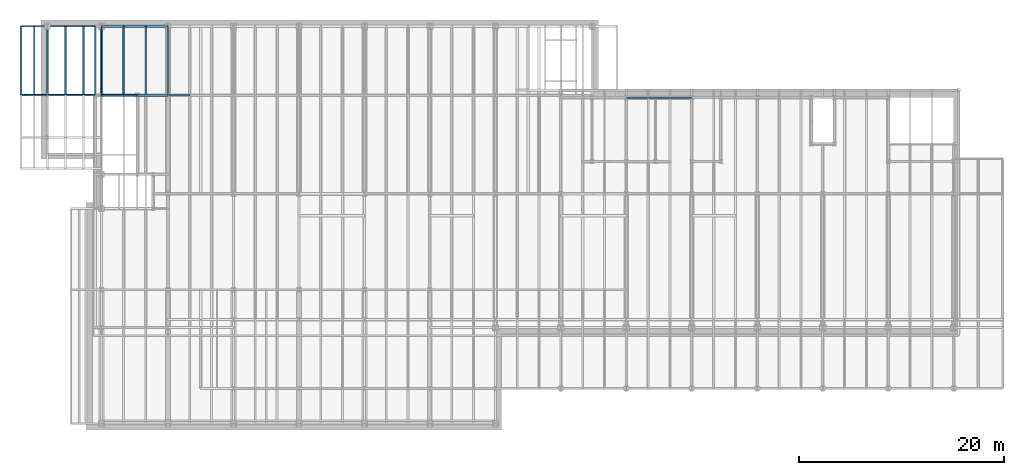
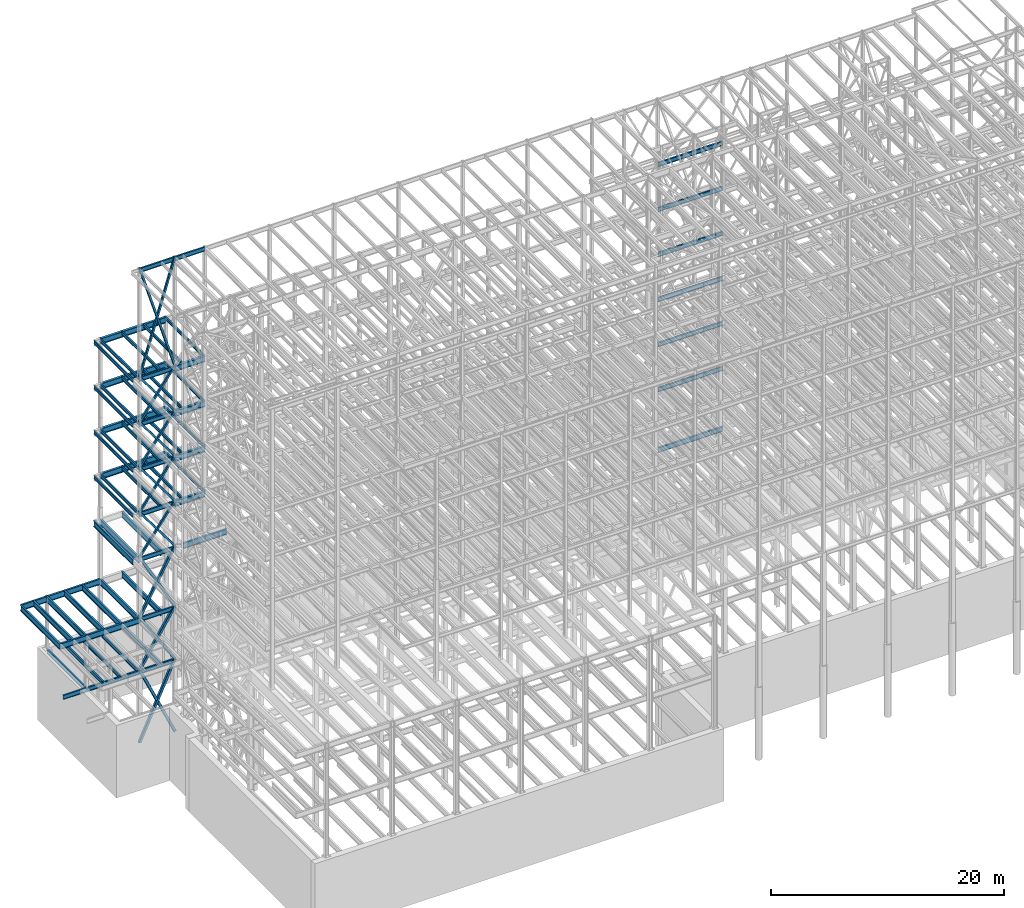
# One storey, part 136 of 150: 81 beams.
"""IFC2X3 building model written with IfcOpenShell, lengths in millimetres."""

import ifcopenshell
import ifcopenshell.guid

model = None  # the IFC model being written
_history = None  # IfcOwnerHistory: only IFC2X3 demands one
_inside = {}  # id of a spatial element -> (the spatial element, [elements in it])
_under = {}  # id of a project, library or spatial element -> (it, [spatial elements below it])
_declared = {}  # id of a project -> (the project, [libraries it declares])
_typed = {}  # id of a type object -> (the type object, [elements of that type])
_made_of = {}  # id of a material, layer set ... -> (it, [elements and type objects made of it])


def new_model(schema):
    """Start an empty IFC model of exactly this schema.

    Asked for "IFC4X3", IfcOpenShell would pick the latest addendum, in which some entities
    have other attributes; the version numbers below select the first issue.
    IFC2X3 requires an IfcOwnerHistory on every rooted entity: one is made here for all.
    """
    global model, _history
    if schema == "IFC4X3":
        model = ifcopenshell.file(schema_version=(4, 3, 0, 0))
    else:
        model = ifcopenshell.file(schema=schema)
    _inside.clear()
    _under.clear()
    _declared.clear()
    _typed.clear()
    _made_of.clear()
    _history = None
    if model.schema == "IFC2X3":
        org = make("IfcOrganization", Name="unknown")
        user = make(
            "IfcPersonAndOrganization",
            ThePerson=make("IfcPerson", FamilyName="unknown"),
            TheOrganization=org,
        )
        app = make(
            "IfcApplication",
            ApplicationDeveloper=org,
            Version="unknown",
            ApplicationFullName="unknown",
            ApplicationIdentifier="unknown",
        )
        _history = make(
            "IfcOwnerHistory",
            OwningUser=user,
            OwningApplication=app,
            ChangeAction="ADDED",
            CreationDate=0,
        )
    return model


def make(cls, **values):
    """One entity of the class cls with the attributes given. An attribute that is None is left unset."""
    return model.create_entity(
        cls, **{name: value for name, value in values.items() if value is not None}
    )


def rooted(cls, **values):
    """An entity with a GlobalId (a new one), such as an element, a storey or a relation."""
    return make(cls, GlobalId=ifcopenshell.guid.new(), OwnerHistory=_history, **values)


def si_unit(unit_type, name, prefix=None):
    """IfcSIUnit, for example si_unit("LENGTHUNIT", "METRE", prefix="MILLI")."""
    return make("IfcSIUnit", UnitType=unit_type, Prefix=prefix, Name=name)


def assignment(units):
    """IfcUnitAssignment: the units of a project."""
    return None if units is None else make("IfcUnitAssignment", Units=units)


def point(xyz):
    """IfcCartesianPoint."""
    return None if xyz is None else make("IfcCartesianPoint", Coordinates=xyz)


def direction(xyz):
    """IfcDirection."""
    return None if xyz is None else make("IfcDirection", DirectionRatios=xyz)


def frame(location, z_axis=None, x_axis=None):
    """IfcAxis2Placement3D, a coordinate frame: its origin and axes. An axis left out is left unset."""
    return make(
        "IfcAxis2Placement3D",
        Location=point(location),
        Axis=direction(z_axis),
        RefDirection=direction(x_axis),
    )


def frame_2d(location, x_axis=None):
    """IfcAxis2Placement2D, a coordinate frame in the plane: its origin and x axis."""
    return make(
        "IfcAxis2Placement2D", Location=point(location), RefDirection=direction(x_axis)
    )


def origin_with_axes():
    """The frame at (0, 0, 0) with the z axis (0, 0, 1) and the x axis (1, 0, 0) written out."""
    return frame((0.0, 0.0, 0.0), z_axis=(0.0, 0.0, 1.0), x_axis=(1.0, 0.0, 0.0))


def origin_2d_with_axis():
    """The frame at (0, 0) in the plane with the x axis (1, 0) written out."""
    return frame_2d((0.0, 0.0), x_axis=(1.0, 0.0))


def place(relative_to, where):
    """IfcLocalPlacement: puts the frame where relative to a parent placement (None: the world)."""
    return make(
        "IfcLocalPlacement", PlacementRelTo=relative_to, RelativePlacement=where
    )


def context(
    kind, dimensions, precision=None, world=None, true_north=None, identifier=None
):
    """IfcGeometricRepresentationContext, for example the 3D "Model" context."""
    return make(
        "IfcGeometricRepresentationContext",
        ContextIdentifier=identifier,
        ContextType=kind,
        CoordinateSpaceDimension=dimensions,
        Precision=precision,
        WorldCoordinateSystem=world,
        TrueNorth=true_north,
    )


def subcontext(parent, identifier, kind, view, scale=None):
    """IfcGeometricRepresentationSubContext, for example "Body" below "Model"."""
    return make(
        "IfcGeometricRepresentationSubContext",
        ContextIdentifier=identifier,
        ContextType=kind,
        ParentContext=parent,
        TargetScale=scale,
        TargetView=view,
    )


def project(units=None, contexts=None):
    """IfcProject with its units and contexts."""
    return rooted(
        "IfcProject",
        Name="project",
        RepresentationContexts=contexts,
        UnitsInContext=assignment(units),
    )


def spatial(cls, under=None, at=None, **own):
    """A site, building, storey or space (cls), placed at a placement, below another one or the project."""
    s = rooted(cls, ObjectPlacement=at, **own)
    if under is not None:
        _under.setdefault(under.id(), (under, []))[1].append(s)
    return s


def profile(cls, at=None, kind="AREA", **sizes):
    """A parametric profile (cls). Its sizes go by their IFC names, for example OverallWidth=200.0."""
    return make(cls, ProfileType=kind, Position=at, **sizes)


def hollow_rectangle(**sizes):
    """IfcRectangleHollowProfileDef."""
    return profile("IfcRectangleHollowProfileDef", **sizes)


def i_section(**sizes):
    """IfcIShapeProfileDef."""
    return profile("IfcIShapeProfileDef", **sizes)


def extrude(swept, where, along, depth):
    """IfcExtrudedAreaSolid: the profile swept, set in the frame where, extruded along a direction by depth."""
    return make(
        "IfcExtrudedAreaSolid",
        SweptArea=swept,
        Position=where,
        ExtrudedDirection=direction(along),
        Depth=depth,
    )


def shape(context_of_items, identifier, shape_type, items):
    """IfcShapeRepresentation: the items that make up one representation, for example the "Body"."""
    return make(
        "IfcShapeRepresentation",
        ContextOfItems=context_of_items,
        RepresentationIdentifier=identifier,
        RepresentationType=shape_type,
        Items=items,
    )


def material(Name=None, Category=None):
    """IfcMaterial."""
    return make("IfcMaterial", Name=Name, Category=Category)


def made_of(thing, what):
    """Note that an element or type object is made of a material, layer set ...; save() writes the relation."""
    if what is not None:
        _made_of.setdefault(what.id(), (what, []))[1].append(thing)
    return thing


def type_object(cls, material=None, **own):
    """A type object (cls), such as IfcWallType, which elements share."""
    return made_of(rooted(cls, **own), material)


def element(
    cls,
    number,
    at=None,
    inside=None,
    cuts=None,
    type_object=None,
    material=None,
    context=None,
    identifier="Body",
    shape_type=None,
    held_by="IfcProductDefinitionShape",
    body=None,
    shapes=None,
    **own,
):
    """One element of the class cls, such as IfcWall. Its Tag is "e" and its number.

    at: its placement. inside: the storey or other place that contains it. cuts: it is an
    opening in that element (IfcRelVoidsElement). A single representation is given by context,
    identifier, shape_type and body (its items); several are given by shapes. held_by: the class
    of the entity that holds the representations. save() writes the other relations.
    """
    e = rooted(cls, Tag="e%d" % number, ObjectPlacement=at, **own)
    if body is not None:
        shapes = [shape(context, identifier, shape_type, body)]
    if shapes is not None:
        e.Representation = make(held_by, Representations=shapes)
    if inside is not None:
        _inside.setdefault(inside.id(), (inside, []))[1].append(e)
    if cuts is not None:
        rooted(
            "IfcRelVoidsElement", RelatingBuildingElement=cuts, RelatedOpeningElement=e
        )
    if type_object is not None:
        _typed.setdefault(type_object.id(), (type_object, []))[1].append(e)
    return made_of(e, material)


def aggregate(whole, parts):
    """IfcRelAggregates: a whole, such as a stair, and the parts it consists of."""
    return rooted("IfcRelAggregates", RelatingObject=whole, RelatedObjects=parts)


def save(model, path):
    """Write the relations noted so far, then the file.

    IfcRelAggregates (storeys below a building ...), IfcRelContainedInSpatialStructure (elements
    in a storey), IfcRelDefinesByType, IfcRelAssociatesMaterial and IfcRelDeclares: one each for
    every whole, place, type object, material and project.
    """
    for whole, parts in _under.values():
        aggregate(whole, parts)
    for where, things in _inside.values():
        rooted(
            "IfcRelContainedInSpatialStructure",
            RelatedElements=things,
            RelatingStructure=where,
        )
    for kind, things in _typed.values():
        rooted("IfcRelDefinesByType", RelatedObjects=things, RelatingType=kind)
    for what, things in _made_of.values():
        rooted("IfcRelAssociatesMaterial", RelatedObjects=things, RelatingMaterial=what)
    for by, libraries in _declared.values():
        rooted("IfcRelDeclares", RelatingContext=by, RelatedDefinitions=libraries)
    model.write(path)


model = new_model("IFC2X3")

# Units and contexts
model_context = context("Model", 3, precision=1e-05, world=origin_with_axes())
body_context = subcontext(model_context, "Body", "Model", "MODEL_VIEW")
ifc_project = project(units=[si_unit("LENGTHUNIT", "METRE", prefix="MILLI"), si_unit("AREAUNIT", "SQUARE_METRE"), si_unit("VOLUMEUNIT", "CUBIC_METRE"), si_unit("MASSUNIT", "GRAM", prefix="KILO"), si_unit("TIMEUNIT", "SECOND"), si_unit("PLANEANGLEUNIT", "RADIAN"), si_unit("SOLIDANGLEUNIT", "STERADIAN"), si_unit("THERMODYNAMICTEMPERATUREUNIT", "DEGREE_CELSIUS"), si_unit("LUMINOUSINTENSITYUNIT", "LUMEN")], contexts=[model_context])

# Site, building, storey
site_placement = place(None, origin_with_axes())
site = spatial("IfcSite", under=ifc_project, at=site_placement, CompositionType="ELEMENT")
building_placement = place(site_placement, origin_with_axes())
building = spatial("IfcBuilding", under=site, at=building_placement, Name="Undefined", CompositionType="ELEMENT")
storey_placement = place(building_placement, origin_with_axes())
storey = spatial("IfcBuildingStorey", under=building, at=storey_placement, Name="Undefined", CompositionType="ELEMENT", Elevation=0.0)

# Beams
ifc_material_1 = material()
beam_type_1 = type_object("IfcBeamType", Name="HSS8X8X3/8", PredefinedType="NOTDEFINED")
beam_1_placement = place(storey_placement, frame((8788.39896651539, 32131.0, 54482.99942554), z_axis=(0.956054251549644, 0.0, 0.293189815808549), x_axis=(-0.293189815808549, 0.0, 0.956054251549644)))
element("IfcBeam", 1, at=beam_1_placement, inside=storey, type_object=beam_type_1, material=ifc_material_1, Name="BEAM", ObjectType="HSS8X8X3/8", context=body_context, shape_type="SweptSolid", body=[
    extrude(hollow_rectangle(XDim=203.2, YDim=203.2, WallThickness=9.525, InnerFilletRadius=9.5249, OuterFilletRadius=19.0499, at=origin_2d_with_axis()), frame((11955.3892837769, -7.27595761418343e-12, -3.63797880709171e-12), z_axis=(-1.0, 0.0, 0.0), x_axis=(0.0, -1.0, 0.0)), (0.0, 0.0, 1.0), 11955.3892837769),
])
beam_2_placement = place(storey_placement, frame((5283.2, 32131.0, 54483.0), z_axis=(-0.956054251549644, 0.0, 0.293189815808549), x_axis=(0.293189815808549, 0.0, 0.956054251549644)))
element("IfcBeam", 2, at=beam_2_placement, inside=storey, type_object=beam_type_1, material=ifc_material_1, Name="BEAM", ObjectType="HSS8X8X3/8", context=body_context, shape_type="SweptSolid", body=[
    extrude(hollow_rectangle(XDim=203.2, YDim=203.2, WallThickness=9.525, InnerFilletRadius=9.5249, OuterFilletRadius=19.0499, at=origin_2d_with_axis()), frame((11955.3887873842, 0.0, 0.0), z_axis=(-1.0, 0.0, 0.0), x_axis=(0.0, -1.0, 0.0)), (0.0, 0.0, 1.0), 11955.3887873842),
])
beam_3_placement = place(storey_placement, frame((8788.39896651539, 32131.0, 40309.79942554), z_axis=(0.803098244341145, 0.0, 0.595846632898241), x_axis=(-0.595846632898242, 0.0, 0.803098244341144)))
element("IfcBeam", 3, at=beam_3_placement, inside=storey, type_object=beam_type_1, material=ifc_material_1, Name="BEAM", ObjectType="HSS8X8X3/8", context=body_context, shape_type="SweptSolid", body=[
    extrude(hollow_rectangle(XDim=203.2, YDim=203.2, WallThickness=9.525, InnerFilletRadius=9.5249, OuterFilletRadius=19.0499, at=origin_2d_with_axis()), frame((5882.7188087498, 0.0, 6.94940112073995e-12), z_axis=(-1.0, 0.0, 0.0), x_axis=(0.0, -1.0, 0.0)), (0.0, 0.0, 1.0), 5882.71880874979),
])
beam_4_placement = place(storey_placement, frame((5283.2, 32131.0, 40309.8), z_axis=(-0.803098029777427, 0.0, 0.595846922092927), x_axis=(0.595846922092929, 0.0, 0.803098029777426)))
element("IfcBeam", 4, at=beam_4_placement, inside=storey, type_object=beam_type_1, material=ifc_material_1, Name="BEAM", ObjectType="HSS8X8X3/8", context=body_context, shape_type="SweptSolid", body=[
    extrude(hollow_rectangle(XDim=203.2, YDim=203.2, WallThickness=9.525, InnerFilletRadius=9.5249, OuterFilletRadius=19.0499, at=origin_2d_with_axis()), frame((5882.71896592564, 0.0, 0.0), z_axis=(-1.0, 0.0, 0.0), x_axis=(0.0, -1.0, 0.0)), (0.0, 0.0, 1.0), 5882.71896592564),
])
beam_5_placement = place(storey_placement, frame((8788.39786397127, 32131.0, 35585.3995776807), z_axis=(0.803098244341145, 0.0, 0.595846632898241), x_axis=(-0.595846632898242, 0.0, 0.803098244341144)))
element("IfcBeam", 5, at=beam_5_placement, inside=storey, type_object=beam_type_1, material=ifc_material_1, Name="BEAM", ObjectType="HSS8X8X3/8", context=body_context, shape_type="SweptSolid", body=[
    extrude(hollow_rectangle(XDim=203.2, YDim=203.2, WallThickness=9.525, InnerFilletRadius=9.5249, OuterFilletRadius=19.0499, at=origin_2d_with_axis()), frame((5882.71803696899, 0.0, 0.0), z_axis=(-1.0, 0.0, 0.0), x_axis=(0.0, -1.0, 0.0)), (0.0, 0.0, 1.0), 5882.71802961862),
])
beam_6_placement = place(storey_placement, frame((5283.2, 32131.0, 35585.4), z_axis=(-0.803098029777427, 0.0, 0.595846922092927), x_axis=(0.595846922092929, 0.0, 0.803098029777426)))
element("IfcBeam", 6, at=beam_6_placement, inside=storey, type_object=beam_type_1, material=ifc_material_1, Name="BEAM", ObjectType="HSS8X8X3/8", context=body_context, shape_type="SweptSolid", body=[
    extrude(hollow_rectangle(XDim=203.2, YDim=203.2, WallThickness=9.525, InnerFilletRadius=9.5249, OuterFilletRadius=19.0499, at=origin_2d_with_axis()), frame((5882.71845468122, 3.63797880709171e-12, -3.63797880709171e-12), z_axis=(-1.0, 0.0, 0.0), x_axis=(0.0, -1.0, 0.0)), (0.0, 0.0, 1.0), 5882.71845468121),
])
ifc_material_2 = material(Name="STEEL/A992")
beam_type_2 = type_object("IfcBeamType", Name="W18X35", PredefinedType="NOTDEFINED")
beam_7_placement = place(storey_placement, frame((8788.39949708, 32130.9985242539, 65687.575), z_axis=(0.0, 0.0, 1.0), x_axis=(1.0, 0.0, 0.0)))
element("IfcBeam", 7, at=beam_7_placement, inside=storey, type_object=beam_type_2, material=ifc_material_2, Name="BEAM", ObjectType="W18X35", context=body_context, shape_type="SweptSolid", body=[
    extrude(i_section(OverallWidth=152.4, OverallDepth=450.85, WebThickness=7.9375, FlangeThickness=10.795, FilletRadius=17.78, at=origin_2d_with_axis()), frame((2997.20050292036, 0.0, 1.45519152283669e-11), z_axis=(-1.0, 0.0, 0.0), x_axis=(0.0, -1.0, 0.0)), (0.0, 0.0, 1.0), 2997.20050292036),
])
beam_8_placement = place(storey_placement, frame((5283.2, 32131.0, 65687.575), z_axis=(0.0, 0.0, 1.0), x_axis=(1.0, 0.0, 0.0)))
element("IfcBeam", 8, at=beam_8_placement, inside=storey, type_object=beam_type_2, material=ifc_material_2, Name="BEAM", ObjectType="W18X35", context=body_context, shape_type="SweptSolid", body=[
    extrude(i_section(OverallWidth=152.4, OverallDepth=450.85, WebThickness=7.9375, FlangeThickness=10.795, FilletRadius=17.78, at=origin_2d_with_axis()), frame((3505.19914656064, 0.0, 1.45519152283669e-11), z_axis=(-1.0, 0.0, 0.0), x_axis=(0.0, -1.0, 0.0)), (0.0, 0.0, 1.0), 3505.19914656064),
])
beam_9_placement = place(storey_placement, frame((56591.2, 31877.0, 58981.975), z_axis=(0.0, 0.0, 1.0), x_axis=(1.0, 0.0, 0.0)))
element("IfcBeam", 9, at=beam_9_placement, inside=storey, type_object=beam_type_2, material=ifc_material_2, Name="BEAM", ObjectType="W18X35", context=body_context, shape_type="SweptSolid", body=[
    extrude(i_section(OverallWidth=152.4, OverallDepth=450.85, WebThickness=7.9375, FlangeThickness=10.795, FilletRadius=17.78, at=origin_2d_with_axis()), frame((6400.80000000001, 0.0, 0.0), z_axis=(-1.0, 0.0, 0.0), x_axis=(0.0, -1.0, 0.0)), (0.0, 0.0, 1.0), 6400.80000000001),
])
beam_10_placement = place(storey_placement, frame((5283.2, 32131.0, 54257.575), z_axis=(0.0, 0.0, 1.0), x_axis=(1.0, 0.0, 0.0)))
element("IfcBeam", 10, at=beam_10_placement, inside=storey, type_object=beam_type_2, material=ifc_material_2, Name="BEAM", ObjectType="W18X35", context=body_context, shape_type="SweptSolid", body=[
    extrude(i_section(OverallWidth=152.4, OverallDepth=450.85, WebThickness=7.9375, FlangeThickness=10.795, FilletRadius=17.78, at=origin_2d_with_axis()), frame((3505.19844552055, 0.0, 0.0), z_axis=(-1.0, 0.0, 0.0), x_axis=(0.0, -1.0, 0.0)), (0.0, 0.0, 1.0), 3505.19844552055),
])
beam_11_placement = place(storey_placement, frame((56591.2, 31877.0, 54257.575), z_axis=(0.0, 0.0, 1.0), x_axis=(1.0, 0.0, 0.0)))
element("IfcBeam", 11, at=beam_11_placement, inside=storey, type_object=beam_type_2, material=ifc_material_2, Name="BEAM", ObjectType="W18X35", context=body_context, shape_type="SweptSolid", body=[
    extrude(i_section(OverallWidth=152.4, OverallDepth=450.85, WebThickness=7.9375, FlangeThickness=10.795, FilletRadius=17.78, at=origin_2d_with_axis()), frame((6400.80000000001, 0.0, 0.0), z_axis=(-1.0, 0.0, 0.0), x_axis=(0.0, -1.0, 0.0)), (0.0, 0.0, 1.0), 6400.8),
])
beam_12_placement = place(storey_placement, frame((5283.2, 32131.0, 49533.175), z_axis=(0.0, 0.0, 1.0), x_axis=(1.0, 0.0, 0.0)))
element("IfcBeam", 12, at=beam_12_placement, inside=storey, type_object=beam_type_2, material=ifc_material_2, Name="BEAM", ObjectType="W18X35", context=body_context, shape_type="SweptSolid", body=[
    extrude(i_section(OverallWidth=152.4, OverallDepth=450.85, WebThickness=7.9375, FlangeThickness=10.795, FilletRadius=17.78, at=origin_2d_with_axis()), frame((3505.19879604036, 0.0, 0.0), z_axis=(-1.0, 0.0, 0.0), x_axis=(0.0, -1.0, 0.0)), (0.0, 0.0, 1.0), 3505.19879604036),
])
beam_13_placement = place(storey_placement, frame((56591.2, 31877.0, 49533.175), z_axis=(0.0, 0.0, 1.0), x_axis=(1.0, 0.0, 0.0)))
element("IfcBeam", 13, at=beam_13_placement, inside=storey, type_object=beam_type_2, material=ifc_material_2, Name="BEAM", ObjectType="W18X35", context=body_context, shape_type="SweptSolid", body=[
    extrude(i_section(OverallWidth=152.4, OverallDepth=450.85, WebThickness=7.9375, FlangeThickness=10.795, FilletRadius=17.78, at=origin_2d_with_axis()), frame((6400.80000000001, 0.0, 0.0), z_axis=(-1.0, 0.0, 0.0), x_axis=(0.0, -1.0, 0.0)), (0.0, 0.0, 1.0), 6400.8),
])
beam_14_placement = place(storey_placement, frame((5283.2, 32131.0, 44808.775), z_axis=(0.0, 0.0, 1.0), x_axis=(1.0, 0.0, 0.0)))
element("IfcBeam", 14, at=beam_14_placement, inside=storey, type_object=beam_type_2, material=ifc_material_2, Name="BEAM", ObjectType="W18X35", context=body_context, shape_type="SweptSolid", body=[
    extrude(i_section(OverallWidth=152.4, OverallDepth=450.85, WebThickness=7.9375, FlangeThickness=10.795, FilletRadius=17.78, at=origin_2d_with_axis()), frame((3505.19914656064, 0.0, 1.45519152283669e-11), z_axis=(-1.0, 0.0, 0.0), x_axis=(0.0, -1.0, 0.0)), (0.0, 0.0, 1.0), 3505.1991465602),
])
beam_15_placement = place(storey_placement, frame((56591.2, 31877.0, 44808.775), z_axis=(0.0, 0.0, 1.0), x_axis=(1.0, 0.0, 0.0)))
element("IfcBeam", 15, at=beam_15_placement, inside=storey, type_object=beam_type_2, material=ifc_material_2, Name="BEAM", ObjectType="W18X35", context=body_context, shape_type="SweptSolid", body=[
    extrude(i_section(OverallWidth=152.4, OverallDepth=450.85, WebThickness=7.9375, FlangeThickness=10.795, FilletRadius=17.78, at=origin_2d_with_axis()), frame((6400.80000000001, 0.0, 0.0), z_axis=(-1.0, 0.0, 0.0), x_axis=(0.0, -1.0, 0.0)), (0.0, 0.0, 1.0), 6400.8),
])
beam_16_placement = place(storey_placement, frame((5283.2, 32131.0, 40084.375), z_axis=(0.0, 0.0, 1.0), x_axis=(1.0, 0.0, 0.0)))
element("IfcBeam", 16, at=beam_16_placement, inside=storey, type_object=beam_type_2, material=ifc_material_2, Name="BEAM", ObjectType="W18X35", context=body_context, shape_type="SweptSolid", body=[
    extrude(i_section(OverallWidth=152.4, OverallDepth=450.85, WebThickness=7.9375, FlangeThickness=10.795, FilletRadius=17.78, at=origin_2d_with_axis()), frame((3505.19949708, 0.0, 0.0), z_axis=(-1.0, 0.0, 0.0), x_axis=(0.0, -1.0, 0.0)), (0.0, 0.0, 1.0), 3505.19949708008),
])
beam_17_placement = place(storey_placement, frame((56591.2, 31877.0, 40084.375), z_axis=(0.0, 0.0, 1.0), x_axis=(1.0, 0.0, 0.0)))
element("IfcBeam", 17, at=beam_17_placement, inside=storey, type_object=beam_type_2, material=ifc_material_2, Name="BEAM", ObjectType="W18X35", context=body_context, shape_type="SweptSolid", body=[
    extrude(i_section(OverallWidth=152.4, OverallDepth=450.85, WebThickness=7.9375, FlangeThickness=10.795, FilletRadius=17.78, at=origin_2d_with_axis()), frame((6400.80000000001, 0.0, 0.0), z_axis=(-1.0, 0.0, 0.0), x_axis=(0.0, -1.0, 0.0)), (0.0, 0.0, 1.0), 6400.8),
])
beam_18_placement = place(storey_placement, frame((5283.2, 32131.0, 35359.975), z_axis=(0.0, 0.0, 1.0), x_axis=(1.0, 0.0, 0.0)))
element("IfcBeam", 18, at=beam_18_placement, inside=storey, type_object=beam_type_2, material=ifc_material_2, Name="BEAM", ObjectType="W18X35", context=body_context, shape_type="SweptSolid", body=[
    extrude(i_section(OverallWidth=152.4, OverallDepth=450.85, WebThickness=7.9375, FlangeThickness=10.795, FilletRadius=17.78, at=origin_2d_with_axis()), frame((3505.19879604036, 0.0, 0.0), z_axis=(-1.0, 0.0, 0.0), x_axis=(0.0, -1.0, 0.0)), (0.0, 0.0, 1.0), 3505.1987960405),
])
beam_19_placement = place(storey_placement, frame((56591.2, 31877.0, 35359.975), z_axis=(0.0, 0.0, 1.0), x_axis=(1.0, 0.0, 0.0)))
element("IfcBeam", 19, at=beam_19_placement, inside=storey, type_object=beam_type_2, material=ifc_material_2, Name="BEAM", ObjectType="W18X35", context=body_context, shape_type="SweptSolid", body=[
    extrude(i_section(OverallWidth=152.4, OverallDepth=450.85, WebThickness=7.9375, FlangeThickness=10.795, FilletRadius=17.78, at=origin_2d_with_axis()), frame((6400.80000000001, 0.0, 0.0), z_axis=(-1.0, 0.0, 0.0), x_axis=(0.0, -1.0, 0.0)), (0.0, 0.0, 1.0), 6400.8),
])
beam_20_placement = place(storey_placement, frame((5283.2, 32131.0, 29060.775), z_axis=(0.0, 0.0, 1.0), x_axis=(1.0, 0.0, 0.0)))
element("IfcBeam", 20, at=beam_20_placement, inside=storey, type_object=beam_type_2, material=ifc_material_2, Name="BEAM", ObjectType="W18X35", context=body_context, shape_type="SweptSolid", body=[
    extrude(i_section(OverallWidth=152.4, OverallDepth=450.85, WebThickness=7.9375, FlangeThickness=10.795, FilletRadius=17.78, at=origin_2d_with_axis()), frame((3505.19949708, 0.0, 0.0), z_axis=(-1.0, 0.0, 0.0), x_axis=(0.0, -1.0, 0.0)), (0.0, 0.0, 1.0), 3505.19949708031),
])
for number, where, z_axis, x_axis, name in (
    (21, (7450.66666666666, 32131.0, 23548.975), (0.0, 0.0, 1.0), (0.0, 1.0, 0.0), "BEAM"),
    (22, (5283.2, 32131.0, 23548.975), (0.0, 0.0, 1.0), (0.0, 1.0, 0.0), "BEAM"),
    (23, (3522.13333333333, 32131.0, 23548.975), (0.0, 0.0, 1.0), (0.0, 1.0, 0.0), "BEAM"),
    (24, (1761.06666666667, 32131.0, 23548.975), (0.0, 0.0, 1.0), (0.0, 1.0, 0.0), "BEAM"),
):
    element("IfcBeam", number, at=place(storey_placement, frame(where, z_axis=z_axis, x_axis=x_axis)), inside=storey, type_object=beam_type_2, material=ifc_material_2, Name=name, ObjectType="W18X35", context=body_context, shape_type="SweptSolid", body=[
        extrude(i_section(OverallWidth=152.4, OverallDepth=450.85, WebThickness=7.9375, FlangeThickness=10.795, FilletRadius=17.78, at=origin_2d_with_axis()), frame((6731.0, 0.0, 0.0), z_axis=(-1.0, 0.0, 0.0), x_axis=(0.0, -1.0, 0.0)), (0.0, 0.0, 1.0), 6731.0),
    ])
beam_21_placement = place(storey_placement, frame((0.0, 32131.0, 23548.975), z_axis=(0.0, 0.0, 1.0), x_axis=(1.0, 0.0, 0.0)))
element("IfcBeam", 25, at=beam_21_placement, inside=storey, type_object=beam_type_2, material=ifc_material_2, Name="BEAM", ObjectType="W18X35", context=body_context, shape_type="SweptSolid", body=[
    extrude(i_section(OverallWidth=152.4, OverallDepth=450.85, WebThickness=7.9375, FlangeThickness=10.795, FilletRadius=17.78, at=origin_2d_with_axis()), frame((5283.2, 0.0, 0.0), z_axis=(-1.0, 0.0, 0.0), x_axis=(0.0, -1.0, 0.0)), (0.0, 0.0, 1.0), 5283.2),
])
beam_22_placement = place(storey_placement, frame((0.0, 32131.0, 23548.975), z_axis=(0.0, 0.0, 1.0), x_axis=(0.0, 1.0, 0.0)))
element("IfcBeam", 26, at=beam_22_placement, inside=storey, type_object=beam_type_2, material=ifc_material_2, Name="BEAM", ObjectType="W18X35", context=body_context, shape_type="SweptSolid", body=[
    extrude(i_section(OverallWidth=152.4, OverallDepth=450.85, WebThickness=7.9375, FlangeThickness=10.795, FilletRadius=17.78, at=origin_2d_with_axis()), frame((6731.0, 0.0, 0.0), z_axis=(-1.0, 0.0, 0.0), x_axis=(0.0, -1.0, 0.0)), (0.0, 0.0, 1.0), 6731.0),
])
beam_23_placement = place(storey_placement, frame((-2286.0, 32131.0, 23548.975), z_axis=(0.0, 0.0, 1.0), x_axis=(1.0, 0.0, 0.0)))
element("IfcBeam", 27, at=beam_23_placement, inside=storey, type_object=beam_type_2, material=ifc_material_2, Name="BEAM", ObjectType="W18X35", context=body_context, shape_type="SweptSolid", body=[
    extrude(i_section(OverallWidth=152.4, OverallDepth=450.85, WebThickness=7.9375, FlangeThickness=10.795, FilletRadius=17.78, at=origin_2d_with_axis()), frame((2286.0, 0.0, 0.0), z_axis=(-1.0, 0.0, 0.0), x_axis=(0.0, -1.0, 0.0)), (0.0, 0.0, 1.0), 2286.0),
])
beam_24_placement = place(storey_placement, frame((5283.2, 32131.0, 23548.975), z_axis=(0.0, 0.0, 1.0), x_axis=(1.0, 0.0, 0.0)))
element("IfcBeam", 28, at=beam_24_placement, inside=storey, type_object=beam_type_2, material=ifc_material_2, Name="BEAM", ObjectType="W18X35", context=body_context, shape_type="SweptSolid", body=[
    extrude(i_section(OverallWidth=152.4, OverallDepth=450.85, WebThickness=7.9375, FlangeThickness=10.795, FilletRadius=17.78, at=origin_2d_with_axis()), frame((3505.19949708, 0.0, 0.0), z_axis=(-1.0, 0.0, 0.0), x_axis=(0.0, -1.0, 0.0)), (0.0, 0.0, 1.0), 3505.19949708008),
])
beam_type_3 = type_object("IfcBeamType", Name="HSS8X8X1/4", PredefinedType="NOTDEFINED")
beam_25_placement = place(storey_placement, frame((8788.39812937003, 32131.0, 49758.5996783069), z_axis=(0.803098244341145, 0.0, 0.595846632898241), x_axis=(-0.595846632898242, 0.0, 0.803098244341144)))
element("IfcBeam", 29, at=beam_25_placement, inside=storey, type_object=beam_type_3, material=ifc_material_1, Name="BEAM", ObjectType="HSS8X8X1/4", context=body_context, shape_type="SweptSolid", body=[
    extrude(hollow_rectangle(XDim=203.2, YDim=203.2, WallThickness=6.35, InnerFilletRadius=6.3499, OuterFilletRadius=12.6999, at=origin_2d_with_axis()), frame((5882.7181069428, 0.0, 0.0), z_axis=(-1.0, 0.0, 0.0), x_axis=(0.0, -1.0, 0.0)), (0.0, 0.0, 1.0), 5882.7181069428),
])
beam_26_placement = place(storey_placement, frame((5283.2, 32131.0, 49758.6), z_axis=(-0.803098029777427, 0.0, 0.595846922092927), x_axis=(0.595846922092929, 0.0, 0.803098029777426)))
element("IfcBeam", 30, at=beam_26_placement, inside=storey, type_object=beam_type_3, material=ifc_material_1, Name="BEAM", ObjectType="HSS8X8X1/4", context=body_context, shape_type="SweptSolid", body=[
    extrude(hollow_rectangle(XDim=203.2, YDim=203.2, WallThickness=6.35, InnerFilletRadius=6.3499, OuterFilletRadius=12.6999, at=origin_2d_with_axis()), frame((5882.71845468122, 3.63797880709171e-12, -3.63797880709171e-12), z_axis=(-1.0, 0.0, 0.0), x_axis=(0.0, -1.0, 0.0)), (0.0, 0.0, 1.0), 5882.71845468122),
])
beam_27_placement = place(storey_placement, frame((8788.39879604043, 32131.0, 45034.2), z_axis=(0.803098244341145, 0.0, 0.595846632898241), x_axis=(-0.595846632898242, 0.0, 0.803098244341144)))
element("IfcBeam", 31, at=beam_27_placement, inside=storey, type_object=beam_type_3, material=ifc_material_1, Name="BEAM", ObjectType="HSS8X8X1/4", context=body_context, shape_type="SweptSolid", body=[
    extrude(hollow_rectangle(XDim=203.2, YDim=203.2, WallThickness=6.35, InnerFilletRadius=6.3499, OuterFilletRadius=12.6999, at=origin_2d_with_axis()), frame((5882.71824582508, 0.0, 0.0), z_axis=(-1.0, 0.0, 0.0), x_axis=(0.0, -1.0, 0.0)), (0.0, 0.0, 1.0), 5882.71824582508),
])
beam_28_placement = place(storey_placement, frame((5283.2, 32131.0, 45034.2), z_axis=(-0.803098029777427, 0.0, 0.595846922092927), x_axis=(0.595846922092929, 0.0, 0.803098029777426)))
element("IfcBeam", 32, at=beam_28_placement, inside=storey, type_object=beam_type_3, material=ifc_material_1, Name="BEAM", ObjectType="HSS8X8X1/4", context=body_context, shape_type="SweptSolid", body=[
    extrude(hollow_rectangle(XDim=203.2, YDim=203.2, WallThickness=6.35, InnerFilletRadius=6.3499, OuterFilletRadius=12.6999, at=origin_2d_with_axis()), frame((5882.71803696899, 0.0, 0.0), z_axis=(-1.0, 0.0, 0.0), x_axis=(0.0, -1.0, 0.0)), (0.0, 0.0, 1.0), 5882.71803696899),
])
beam_type_4 = type_object("IfcBeamType", Name="HSS10X10X1/2", PredefinedType="NOTDEFINED")
beam_29_placement = place(storey_placement, frame((8788.39874568066, 32131.0, 29286.199821557), z_axis=(0.873824736521028, 0.0, 0.486241020322181), x_axis=(-0.486241020322179, 0.0, 0.87382473652103)))
element("IfcBeam", 33, at=beam_29_placement, inside=storey, type_object=beam_type_4, material=ifc_material_1, Name="BEAM", ObjectType="HSS10X10X1/2", context=body_context, shape_type="SweptSolid", body=[
    extrude(hollow_rectangle(XDim=254.0, YDim=254.0, WallThickness=12.7, InnerFilletRadius=12.6999, OuterFilletRadius=25.3999, at=origin_2d_with_axis()), frame((7208.76835075297, 0.0, 0.0), z_axis=(-1.0, 0.0, 0.0), x_axis=(0.0, -1.0, 0.0)), (0.0, 0.0, 1.0), 7208.76835075297),
])
beam_30_placement = place(storey_placement, frame((5283.2, 32131.0, 29286.2), z_axis=(-0.873824779009973, 0.0, 0.486240943965204), x_axis=(0.486240943965203, 0.0, 0.873824779009973)))
element("IfcBeam", 34, at=beam_30_placement, inside=storey, type_object=beam_type_4, material=ifc_material_1, Name="BEAM", ObjectType="HSS10X10X1/2", context=body_context, shape_type="SweptSolid", body=[
    extrude(hollow_rectangle(XDim=254.0, YDim=254.0, WallThickness=12.7, InnerFilletRadius=12.6999, OuterFilletRadius=25.3999, at=origin_2d_with_axis()), frame((7208.76804887501, -3.63797880709171e-12, 4.0016701335216e-13), z_axis=(-1.0, 0.0, 0.0), x_axis=(0.0, -1.0, 0.0)), (0.0, 0.0, 1.0), 7208.76804887501),
])
beam_31_placement = place(storey_placement, frame((8788.39804318086, 32131.0, 23774.3999398151), z_axis=(0.843821721320064, 0.0, 0.536623613558372), x_axis=(-0.536623613558373, 0.0, 0.843821721320063)))
element("IfcBeam", 35, at=beam_31_placement, inside=storey, type_object=beam_type_4, material=ifc_material_1, Name="BEAM", ObjectType="HSS10X10X1/2", context=body_context, shape_type="SweptSolid", body=[
    extrude(hollow_rectangle(XDim=254.0, YDim=254.0, WallThickness=12.7, InnerFilletRadius=12.6999, OuterFilletRadius=25.3999, at=origin_2d_with_axis()), frame((6531.9486545267, 0.0, 0.0), z_axis=(-1.0, 0.0, 0.0), x_axis=(0.0, -1.0, 0.0)), (0.0, 0.0, 1.0), 6531.9486545267),
])
beam_32_placement = place(storey_placement, frame((5283.2, 32131.0, 23774.4), z_axis=(-0.843821647242095, 0.0, 0.53662373004335), x_axis=(0.53662373004335, 0.0, 0.843821647242095)))
element("IfcBeam", 36, at=beam_32_placement, inside=storey, type_object=beam_type_4, material=ifc_material_1, Name="BEAM", ObjectType="HSS10X10X1/2", context=body_context, shape_type="SweptSolid", body=[
    extrude(hollow_rectangle(XDim=254.0, YDim=254.0, WallThickness=12.7, InnerFilletRadius=12.6999, OuterFilletRadius=25.3999, at=origin_2d_with_axis()), frame((6531.94919584127, -7.27595761418343e-12, 0.0), z_axis=(-1.0, 0.0, 0.0), x_axis=(0.0, -1.0, 0.0)), (0.0, 0.0, 1.0), 6531.94919584127),
])
for number, where, z_axis, x_axis, name in (
    (37, (8788.39879604043, 32131.0, 16154.4), (0.908490540001108, 0.0, 0.417905418400499), (-0.417905418400499, 0.0, 0.908490540001108), "BEAM"),
    (38, (5283.2, 32131.0, 16154.4), (-0.908490540001108, 0.0, 0.417905418400499), (0.417905418400499, 0.0, 0.908490540001107), "BEAM"),
):
    element("IfcBeam", number, at=place(storey_placement, frame(where, z_axis=z_axis, x_axis=x_axis)), inside=storey, type_object=beam_type_4, material=ifc_material_1, Name=name, ObjectType="HSS10X10X1/2", context=body_context, shape_type="SweptSolid", body=[
        extrude(hollow_rectangle(XDim=254.0, YDim=254.0, WallThickness=12.7, InnerFilletRadius=12.6999, OuterFilletRadius=25.3999, at=origin_2d_with_axis()), frame((8387.53948424466, 0.0, 3.63797880709171e-12), z_axis=(-1.0, 0.0, 0.0), x_axis=(0.0, -1.0, 0.0)), (0.0, 0.0, 1.0), 8387.53948424467),
    ])
beam_type_5 = type_object("IfcBeamType", Name="W24X68", PredefinedType="NOTDEFINED")
beam_33_placement = place(storey_placement, frame((8788.39914656027, 32130.9992989537, 54181.375), z_axis=(0.0, 0.0, 1.0), x_axis=(1.0, 0.0, 0.0)))
element("IfcBeam", 39, at=beam_33_placement, inside=storey, type_object=beam_type_5, material=ifc_material_2, Name="BEAM", ObjectType="W24X68", context=body_context, shape_type="SweptSolid", body=[
    extrude(i_section(OverallWidth=227.838, OverallDepth=603.25, WebThickness=11.1125, FlangeThickness=14.859, FilletRadius=23.2409, at=origin_2d_with_axis()), frame((2997.19995427982, 0.0, 0.0), z_axis=(-1.0, 0.0, 0.0), x_axis=(0.0, -1.0, 0.0)), (0.0, 0.0, 1.0), 2997.19995427982),
])
beam_34_placement = place(storey_placement, frame((5283.2, 38862.0, 54181.375), z_axis=(0.0, 0.0, 1.0), x_axis=(1.0, 0.0, 0.0)))
element("IfcBeam", 40, at=beam_34_placement, inside=storey, type_object=beam_type_5, material=ifc_material_2, Name="BEAM", ObjectType="W24X68", context=body_context, shape_type="SweptSolid", body=[
    extrude(i_section(OverallWidth=227.838, OverallDepth=603.25, WebThickness=11.1125, FlangeThickness=14.859, FilletRadius=23.2409, at=origin_2d_with_axis()), frame((6502.4, 0.0, 0.0), z_axis=(-1.0, 0.0, 0.0), x_axis=(0.0, -1.0, 0.0)), (0.0, 0.0, 1.0), 6502.4),
])
beam_35_placement = place(storey_placement, frame((8788.39914656027, 32130.9992989537, 49456.975), z_axis=(0.0, 0.0, 1.0), x_axis=(1.0, 0.0, 0.0)))
element("IfcBeam", 41, at=beam_35_placement, inside=storey, type_object=beam_type_5, material=ifc_material_2, Name="BEAM", ObjectType="W24X68", context=body_context, shape_type="SweptSolid", body=[
    extrude(i_section(OverallWidth=227.838, OverallDepth=603.25, WebThickness=11.1125, FlangeThickness=14.859, FilletRadius=23.2409, at=origin_2d_with_axis()), frame((2997.20025399979, 0.0, 0.0), z_axis=(-1.0, 0.0, 0.0), x_axis=(0.0, -1.0, 0.0)), (0.0, 0.0, 1.0), 2997.20025399979),
])
beam_36_placement = place(storey_placement, frame((5283.2, 38862.0, 49456.975), z_axis=(0.0, 0.0, 1.0), x_axis=(1.0, 0.0, 0.0)))
element("IfcBeam", 42, at=beam_36_placement, inside=storey, type_object=beam_type_5, material=ifc_material_2, Name="BEAM", ObjectType="W24X68", context=body_context, shape_type="SweptSolid", body=[
    extrude(i_section(OverallWidth=227.838, OverallDepth=603.25, WebThickness=11.1125, FlangeThickness=14.859, FilletRadius=23.2409, at=origin_2d_with_axis()), frame((6502.4, 0.0, 0.0), z_axis=(-1.0, 0.0, 0.0), x_axis=(0.0, -1.0, 0.0)), (0.0, 0.0, 1.0), 6502.4),
])
beam_37_placement = place(storey_placement, frame((8788.39914656027, 32130.9992989537, 44732.575), z_axis=(0.0, 0.0, 1.0), x_axis=(1.0, 0.0, 0.0)))
element("IfcBeam", 43, at=beam_37_placement, inside=storey, type_object=beam_type_5, material=ifc_material_2, Name="BEAM", ObjectType="W24X68", context=body_context, shape_type="SweptSolid", body=[
    extrude(i_section(OverallWidth=227.838, OverallDepth=603.25, WebThickness=11.1125, FlangeThickness=14.859, FilletRadius=23.2409, at=origin_2d_with_axis()), frame((2997.20055371978, 7.93352380790465e-20, 0.0), z_axis=(-1.0, 0.0, 0.0), x_axis=(0.0, -1.0, 0.0)), (0.0, 0.0, 1.0), 2997.20055371978),
])
beam_38_placement = place(storey_placement, frame((5283.2, 38862.0, 44732.575), z_axis=(0.0, 0.0, 1.0), x_axis=(1.0, 0.0, 0.0)))
element("IfcBeam", 44, at=beam_38_placement, inside=storey, type_object=beam_type_5, material=ifc_material_2, Name="BEAM", ObjectType="W24X68", context=body_context, shape_type="SweptSolid", body=[
    extrude(i_section(OverallWidth=227.838, OverallDepth=603.25, WebThickness=11.1125, FlangeThickness=14.859, FilletRadius=23.2409, at=origin_2d_with_axis()), frame((6502.4, 0.0, 0.0), z_axis=(-1.0, 0.0, 0.0), x_axis=(0.0, -1.0, 0.0)), (0.0, 0.0, 1.0), 6502.4),
])
beam_39_placement = place(storey_placement, frame((8788.39914656027, 32130.9992989537, 40008.175), z_axis=(0.0, 0.0, 1.0), x_axis=(1.0, 0.0, 0.0)))
element("IfcBeam", 45, at=beam_39_placement, inside=storey, type_object=beam_type_5, material=ifc_material_2, Name="BEAM", ObjectType="W24X68", context=body_context, shape_type="SweptSolid", body=[
    extrude(i_section(OverallWidth=227.838, OverallDepth=603.25, WebThickness=11.1125, FlangeThickness=14.859, FilletRadius=23.2409, at=origin_2d_with_axis()), frame((2997.20085343981, 0.0, 0.0), z_axis=(-1.0, 0.0, 0.0), x_axis=(0.0, -1.0, 0.0)), (0.0, 0.0, 1.0), 2997.20085343981),
])
beam_40_placement = place(storey_placement, frame((5283.2, 38862.0, 40008.175), z_axis=(0.0, 0.0, 1.0), x_axis=(1.0, 0.0, 0.0)))
element("IfcBeam", 46, at=beam_40_placement, inside=storey, type_object=beam_type_5, material=ifc_material_2, Name="BEAM", ObjectType="W24X68", context=body_context, shape_type="SweptSolid", body=[
    extrude(i_section(OverallWidth=227.838, OverallDepth=603.25, WebThickness=11.1125, FlangeThickness=14.859, FilletRadius=23.2409, at=origin_2d_with_axis()), frame((6502.4, 0.0, 0.0), z_axis=(-1.0, 0.0, 0.0), x_axis=(0.0, -1.0, 0.0)), (0.0, 0.0, 1.0), 6502.4),
])
beam_type_6 = type_object("IfcBeamType", Name="W14X22", PredefinedType="NOTDEFINED")
for number, where, z_axis, x_axis, name in (
    (47, (11785.6, 32131.0, 54308.375), (0.0, 0.0, 1.0), (0.0, 1.0, 0.0), "BEAM"),
    (48, (9618.13333333333, 32131.0, 54308.375), (0.0, 0.0, 1.0), (0.0, 1.0, 0.0), "BEAM"),
    (49, (7450.66666666667, 32131.0, 54308.375), (0.0, 0.0, 1.0), (0.0, 1.0, 0.0), "BEAM"),
    (50, (5283.2, 32131.0, 54308.375), (0.0, 0.0, 1.0), (0.0, 1.0, 0.0), "BEAM"),
    (51, (4673.6, 32131.0, 54308.375), (0.0, 0.0, 1.0), (0.0, 1.0, 0.0), "BEAM"),
    (52, (11785.6, 32131.0, 49583.975), (0.0, 0.0, 1.0), (0.0, 1.0, 0.0), "BEAM"),
    (53, (9618.13333333333, 32131.0, 49583.975), (0.0, 0.0, 1.0), (0.0, 1.0, 0.0), "BEAM"),
    (54, (7450.66666666667, 32131.0, 49583.975), (0.0, 0.0, 1.0), (0.0, 1.0, 0.0), "BEAM"),
    (55, (5283.2, 32131.0, 49583.975), (0.0, 0.0, 1.0), (0.0, 1.0, 0.0), "BEAM"),
    (56, (4673.6, 32131.0, 49583.975), (0.0, 0.0, 1.0), (0.0, 1.0, 0.0), "BEAM"),
    (57, (11785.6, 32131.0, 44859.575), (0.0, 0.0, 1.0), (0.0, 1.0, 0.0), "BEAM"),
    (58, (9618.13333333333, 32131.0, 44859.575), (0.0, 0.0, 1.0), (0.0, 1.0, 0.0), "BEAM"),
    (59, (7450.66666666667, 32131.0, 44859.575), (0.0, 0.0, 1.0), (0.0, 1.0, 0.0), "BEAM"),
    (60, (5283.2, 32131.0, 44859.575), (0.0, 0.0, 1.0), (0.0, 1.0, 0.0), "BEAM"),
    (61, (4673.6, 32131.0, 44859.575), (0.0, 0.0, 1.0), (0.0, 1.0, 0.0), "BEAM"),
    (62, (11785.6, 32131.0, 40135.175), (0.0, 0.0, 1.0), (0.0, 1.0, 0.0), "BEAM"),
    (63, (9618.13333333333, 32131.0, 40135.175), (0.0, 0.0, 1.0), (0.0, 1.0, 0.0), "BEAM"),
    (64, (7450.66666666667, 32131.0, 40135.175), (0.0, 0.0, 1.0), (0.0, 1.0, 0.0), "BEAM"),
    (65, (5283.2, 32131.0, 40135.175), (0.0, 0.0, 1.0), (0.0, 1.0, 0.0), "BEAM"),
    (66, (4673.6, 32131.0, 40135.175), (0.0, 0.0, 1.0), (0.0, 1.0, 0.0), "BEAM"),
):
    element("IfcBeam", number, at=place(storey_placement, frame(where, z_axis=z_axis, x_axis=x_axis)), inside=storey, type_object=beam_type_6, material=ifc_material_2, Name=name, ObjectType="W14X22", context=body_context, shape_type="SweptSolid", body=[
        extrude(i_section(OverallWidth=127.0, OverallDepth=349.25, WebThickness=6.3499, FlangeThickness=8.509, FilletRadius=18.4785, at=origin_2d_with_axis()), frame((6731.0, 0.0, 0.0), z_axis=(-1.0, 0.0, 0.0), x_axis=(0.0, -1.0, 0.0)), (0.0, 0.0, 1.0), 6731.0),
    ])
beam_type_7 = type_object("IfcBeamType", Name="W24X55", PredefinedType="NOTDEFINED")
for number, where, z_axis, x_axis, name in (
    (67, (-1295.4, 32131.0, 28986.1625), (0.0, 0.0, 1.0), (0.0, 1.0, 0.0), "BEAM"),
    (68, (7450.66644992, 32131.0, 28986.1625), (0.0, 0.0, 1.0), (0.0, 1.0, 0.0), "BEAM"),
    (69, (5283.2, 32131.0, 28986.1625), (0.0, 0.0, 1.0), (0.0, 1.0, 0.0), "BEAM"),
    (70, (3522.13333333333, 32131.0, 28986.1625), (0.0, 0.0, 1.0), (0.0, 1.0, 0.0), "BEAM"),
    (71, (1761.06666666667, 32131.0, 28986.1625), (0.0, 0.0, 1.0), (0.0, 1.0, 0.0), "BEAM"),
    (72, (0.0, 32131.0, 28986.1625), (0.0, 0.0, 1.0), (0.0, 1.0, 0.0), "BEAM"),
    (73, (-2590.8, 32131.0, 28986.1625), (0.0, 0.0, 1.0), (0.0, 1.0, 0.0), "BEAM"),
):
    element("IfcBeam", number, at=place(storey_placement, frame(where, z_axis=z_axis, x_axis=x_axis)), inside=storey, type_object=beam_type_7, material=ifc_material_2, Name=name, ObjectType="W24X55", context=body_context, shape_type="SweptSolid", body=[
        extrude(i_section(OverallWidth=178.054, OverallDepth=600.075, WebThickness=9.5249, FlangeThickness=12.827, FilletRadius=23.6854, at=origin_2d_with_axis()), frame((6731.0, 0.0, 0.0), z_axis=(-1.0, 0.0, 0.0), x_axis=(0.0, -1.0, 0.0)), (0.0, 0.0, 1.0), 6731.0),
    ])
for number, where, z_axis, x_axis, name in (
    (74, (-2590.8, 32131.0, 28986.1625), (0.0, 0.0, 1.0), (1.0, 0.0, 0.0), "BEAM"),
    (75, (-2590.8, 38862.0, 28986.1625), (0.0, 0.0, 1.0), (1.0, 0.0, 0.0), "BEAM"),
):
    element("IfcBeam", number, at=place(storey_placement, frame(where, z_axis=z_axis, x_axis=x_axis)), inside=storey, type_object=beam_type_7, material=ifc_material_2, Name=name, ObjectType="W24X55", context=body_context, shape_type="SweptSolid", body=[
        extrude(i_section(OverallWidth=178.054, OverallDepth=600.075, WebThickness=9.5249, FlangeThickness=12.827, FilletRadius=23.6854, at=origin_2d_with_axis()), frame((7874.0, 0.0, 0.0), z_axis=(-1.0, 0.0, 0.0), x_axis=(0.0, -1.0, 0.0)), (0.0, 0.0, 1.0), 7874.0),
    ])
beam_type_8 = type_object("IfcBeamType", Name="W21X44", PredefinedType="NOTDEFINED")
beam_41_placement = place(storey_placement, frame((56591.2, 31877.0, 29024.2625), z_axis=(0.0, 0.0, 1.0), x_axis=(1.0, 0.0, 0.0)))
element("IfcBeam", 76, at=beam_41_placement, inside=storey, type_object=beam_type_8, material=ifc_material_2, Name="BEAM", ObjectType="W21X44", context=body_context, shape_type="SweptSolid", body=[
    extrude(i_section(OverallWidth=165.1, OverallDepth=523.875, WebThickness=9.5249, FlangeThickness=11.43, FilletRadius=17.145, at=origin_2d_with_axis()), frame((6400.80000000001, 0.0, 0.0), z_axis=(-1.0, 0.0, 0.0), x_axis=(0.0, -1.0, 0.0)), (0.0, 0.0, 1.0), 6400.80000000001),
])
beam_type_9 = type_object("IfcBeamType", Name="W24X62", PredefinedType="NOTDEFINED")
for number, where, z_axis, x_axis, name in (
    (77, (4673.6, 32131.0, 35283.775), (0.0, 0.0, 1.0), (0.0, 1.0, 0.0), "BEAM"),
    (78, (5283.2, 32131.0, 35283.775), (0.0, 0.0, 1.0), (0.0, 1.0, 0.0), "BEAM"),
    (79, (7450.66666666666, 32131.0, 35283.775), (0.0, 0.0, 1.0), (0.0, 1.0, 0.0), "BEAM"),
):
    element("IfcBeam", number, at=place(storey_placement, frame(where, z_axis=z_axis, x_axis=x_axis)), inside=storey, type_object=beam_type_9, material=ifc_material_2, Name=name, ObjectType="W24X62", context=body_context, shape_type="SweptSolid", body=[
        extrude(i_section(OverallWidth=177.8, OverallDepth=603.25, WebThickness=11.1125, FlangeThickness=14.986, FilletRadius=23.114, at=origin_2d_with_axis()), frame((6731.0, 0.0, 0.0), z_axis=(-1.0, 0.0, 0.0), x_axis=(0.0, -1.0, 0.0)), (0.0, 0.0, 1.0), 6731.0),
    ])
beam_42_placement = place(storey_placement, frame((9618.13333333333, 32131.0, 35283.775), z_axis=(0.0, 0.0, 1.0), x_axis=(1.0, 0.0, 0.0)))
element("IfcBeam", 80, at=beam_42_placement, inside=storey, type_object=beam_type_9, material=ifc_material_2, Name="BEAM", ObjectType="W24X62", context=body_context, shape_type="SweptSolid", body=[
    extrude(i_section(OverallWidth=177.8, OverallDepth=603.25, WebThickness=11.1125, FlangeThickness=14.986, FilletRadius=23.114, at=origin_2d_with_axis()), frame((2167.46666666666, 0.0, 0.0), z_axis=(-1.0, 0.0, 0.0), x_axis=(0.0, -1.0, 0.0)), (0.0, 0.0, 1.0), 2167.46666666666),
])
beam_43_placement = place(storey_placement, frame((11785.6, 32131.0, 35283.775), z_axis=(0.0, 0.0, 1.0), x_axis=(1.0, 0.0, 0.0)))
element("IfcBeam", 81, at=beam_43_placement, inside=storey, type_object=beam_type_9, material=ifc_material_2, Name="BEAM", ObjectType="W24X62", context=body_context, shape_type="SweptSolid", body=[
    extrude(i_section(OverallWidth=177.8, OverallDepth=603.25, WebThickness=11.1125, FlangeThickness=14.986, FilletRadius=23.114, at=origin_2d_with_axis()), frame((2133.6, 0.0, 0.0), z_axis=(-1.0, 0.0, 0.0), x_axis=(0.0, -1.0, 0.0)), (0.0, 0.0, 1.0), 2133.6),
])

save(model, "model.ifc")
